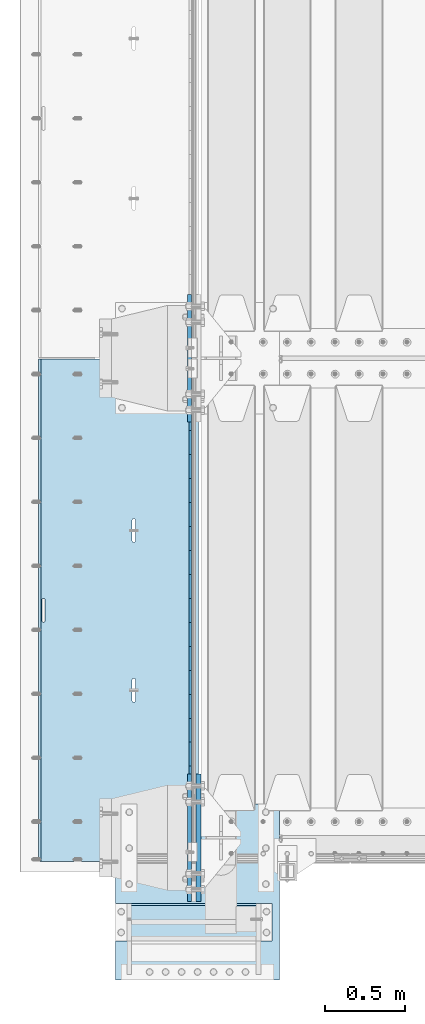
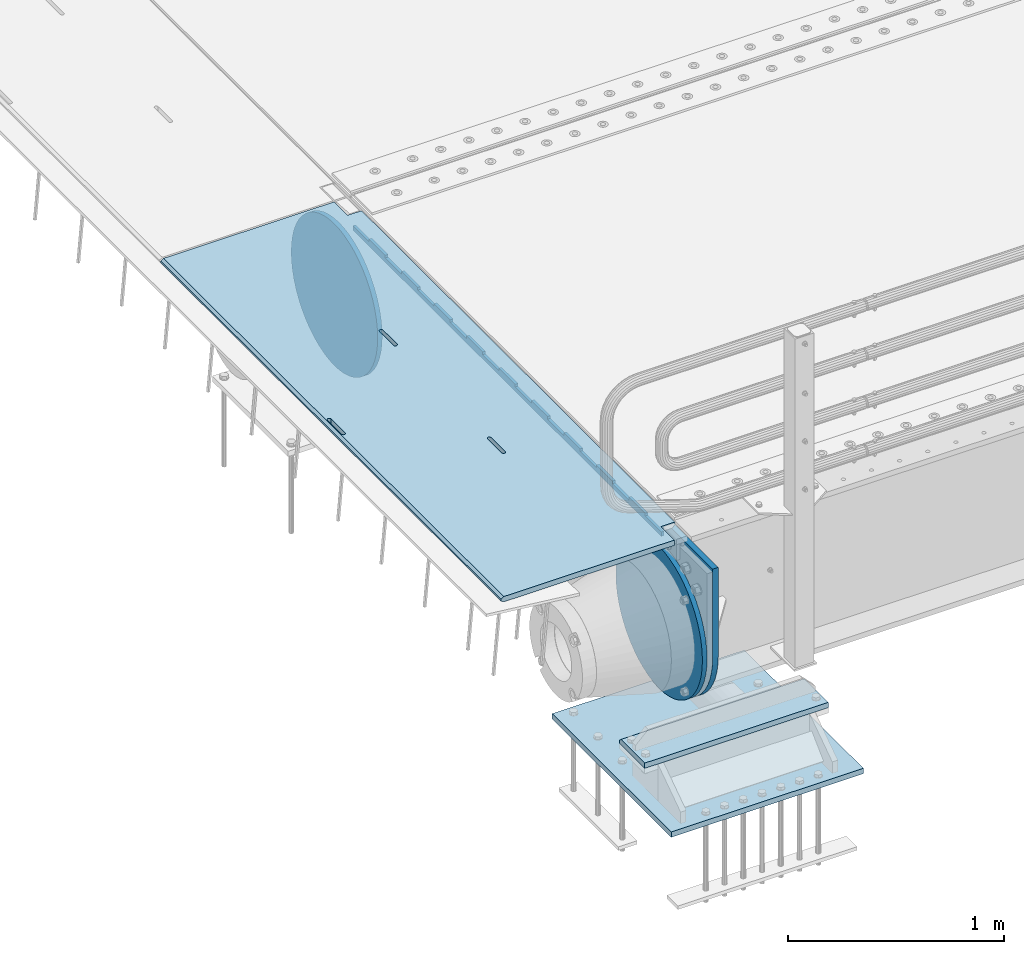
# One storey, part 189 of 247: 7 plates.
"""IFC2X3 building model written with IfcOpenShell, lengths in millimetres."""

from ifc_helpers import new_model, si_unit, frame, origin_with_axes, place, context, subcontext, project, spatial, faceted_brep, material, type_object, element, save


model = new_model("IFC2X3")

# Units and contexts
model_context = context("Model", 3, precision=1e-05, world=origin_with_axes())
body_context = subcontext(model_context, "Body", "Model", "MODEL_VIEW")
ifc_project = project(units=[si_unit("LENGTHUNIT", "METRE", prefix="MILLI"), si_unit("AREAUNIT", "SQUARE_METRE"), si_unit("VOLUMEUNIT", "CUBIC_METRE"), si_unit("MASSUNIT", "GRAM", prefix="KILO"), si_unit("TIMEUNIT", "SECOND"), si_unit("PLANEANGLEUNIT", "RADIAN"), si_unit("SOLIDANGLEUNIT", "STERADIAN"), si_unit("THERMODYNAMICTEMPERATUREUNIT", "DEGREE_CELSIUS"), si_unit("LUMINOUSINTENSITYUNIT", "LUMEN")], contexts=[model_context])

# Site, building, storey
site_placement = place(None, origin_with_axes())
site = spatial("IfcSite", under=ifc_project, at=site_placement, CompositionType="ELEMENT")
building_placement = place(site_placement, origin_with_axes())
building = spatial("IfcBuilding", under=site, at=building_placement, Name="Standard", CompositionType="ELEMENT")
storey_placement = place(building_placement, origin_with_axes())
storey = spatial("IfcBuildingStorey", under=building, at=storey_placement, Name="Undefined", CompositionType="ELEMENT", Elevation=0.0)

# Plates
ifc_material_1 = material(Name="STEEL/S355N")
plate_type_1 = type_object("IfcPlateType", PredefinedType="NOTDEFINED")
plate_1_placement = place(storey_placement, frame((-5.00375457088524, 2994.99992612933, -0.984429074950507), z_axis=(1.00000000012752e-09, -0.999999999987744, -4.95099999993936e-06), x_axis=(-0.999999999879068, -1.00000022172504e-09, -1.55519999981193e-05)))
element("IfcPlate", 1, at=plate_1_placement, inside=storey, type_object=plate_type_1, material=ifc_material_1, context=body_context, shape_type="Brep", body=[
    faceted_brep([(14.9998601691701, 15.0, 125.000024820866), (-0.000294611402138933, -0.00080690296905217, 124.999936248667), (-0.00191941583158695, 0.000806844427329922, 3020.00000492307), (14.9966216875132, 15.0, 3020.00007976655), (999.996459960937, 5.0, 1.36424205265939e-12), (984.996459960937, 15.0, 1.36424205265939e-12), (984.996459718778, 15.0, 3145.0), (999.996459718778, 5.0, 3145.0), (984.996459961366, -15.0, 1.81898940354586e-12), (999.996459960937, -4.99999999999999, 1.81898940354586e-12), (999.996459718778, -4.99999999999999, 3145.0), (984.996459719206, -15.0, 3145.0), (394.996621833771, -15.0000000044172, 1137.49999999819), (394.996621833771, 15.0, 1137.49999999819), (395.486056670582, 15.0, 1140.59016994194), (395.486056670582, -15.0000000044093, 1140.59016994194), (396.906451889569, 15.0, 1143.37785252112), (396.906451889569, -15.0000000043835, 1143.37785252112), (399.118769310224, 15.0, 1145.59016994194), (399.118769310224, -15.0000000043424, 1145.59016994194), (401.90645188929, 15.0, 1147.01056516114), (401.90645188929, -15.00000000429, 1147.01056516114), (404.996621832993, 15.0, 1147.49999999819), (404.996621832993, -15.0000000042314, 1147.49999999819), (408.086791776782, 15.0, 1147.01056516114), (408.086791776782, -15.0000000041723, 1147.01056516114), (410.874474356068, 15.0, 1145.59016994194), (410.874474356068, -15.0000000041186, 1145.59016994194), (413.086791777063, 15.0, 1143.37785252111), (413.086791777063, -15.0000000040755, 1143.37785252111), (414.507186996479, 15.0, 1140.59016994194), (414.507186996479, -15.0000000040472, 1140.59016994194), (414.996621833763, 15.0, 1137.49999999818), (414.996621833763, -15.0000000040365, 1137.49999999818), (414.996621843667, 15.0, 1007.49999999818), (414.996621843667, -15.000000003978, 1007.49999999818), (414.507187006854, 15.0, 1004.40983005444), (414.507187006854, -15.000000003986, 1004.40983005444), (413.086791787866, 15.0, 1001.62214747526), (413.086791787866, -15.0000000040118, 1001.62214747526), (410.874474367212, 15.0, 999.409830054441), (410.874474367212, -15.0000000040529, 999.409830054441), (408.086791788147, 15.0, 997.989434835241), (408.086791788147, -15.0000000041053, 997.989434835241), (404.996621844551, 15.0, 997.499999998192), (404.996621844551, -15.0000000041639, 997.499999998193), (401.906451900764, 15.0, 997.989434835241), (401.906451900764, -15.000000004223, 997.989434835241), (399.118769321479, 15.0, 999.409830054443), (399.118769321479, -15.0000000042767, 999.409830054443), (396.906451900484, 15.0, 1001.62214747527), (396.906451900484, -15.0000000043198, 1001.62214747527), (395.486056681068, 15.0, 1004.40983005444), (395.486056681068, -15.0000000043481, 1004.40983005444), (394.996621843781, 15.0, 1007.49999999819), (394.996621843781, -15.0000000043588, 1007.49999999819), (960.486056642574, -15.0, 1504.4098300542), (960.486056642574, 15.0, 1504.4098300542), (959.996621805288, 15.0, 1507.49999999795), (959.996621805288, -15.0, 1507.49999999795), (961.906451861991, -15.0, 1501.62214747502), (961.906451861991, 15.0, 1501.62214747502), (964.118769282986, -15.0, 1499.4098300542), (964.118769282986, 15.0, 1499.4098300542), (966.906451862271, -15.0, 1497.98943483499), (966.906451862271, 15.0, 1497.98943483499), (969.996621806058, -15.0, 1497.49999999795), (969.996621806058, 15.0, 1497.49999999795), (973.086791749653, -15.0, 1497.98943483499), (973.086791749654, 15.0, 1497.98943483499), (975.874474328718, -15.0, 1499.40983005419), (975.874474328718, 15.0, 1499.40983005419), (978.086791749372, -15.0, 1501.62214747502), (978.086791749372, 15.0, 1501.62214747502), (979.507186968361, -15.0, 1504.40983005419), (979.507186968361, 15.0, 1504.40983005419), (979.996621805173, -15.0, 1507.49999999794), (979.996621805173, 15.0, 1507.49999999794), (979.99662179527, -15.0, 1637.49999999794), (979.99662179527, 15.0, 1637.49999999794), (979.507186957986, -15.0, 1640.59016994169), (979.507186957985, 15.0, 1640.59016994169), (978.08679173857, -15.0, 1643.37785252087), (978.08679173857, 15.0, 1643.37785252087), (975.874474317574, -15.0, 1645.59016994169), (975.874474317574, 15.0, 1645.59016994169), (973.086791738289, -15.0, 1647.0105651609), (973.086791738289, 15.0, 1647.0105651609), (969.9966217945, -15.0, 1647.49999999795), (969.9966217945, 15.0, 1647.49999999795), (966.906451850796, -15.0, 1647.0105651609), (966.906451850796, 15.0, 1647.0105651609), (964.11876927173, -15.0, 1645.5901699417), (964.11876927173, 15.0, 1645.5901699417), (961.906451851076, -15.0, 1643.37785252087), (961.906451851076, 15.0, 1643.37785252087), (960.486056632089, -15.0, 1640.5901699417), (960.486056632089, 15.0, 1640.5901699417), (959.996621795278, -15.0, 1637.49999999795), (959.996621795278, 15.0, 1637.49999999795), (-0.000449375328786417, -14.9999999951864, 124.99986141778), (-0.000460362207132192, -15.00000004538, 3019.99993008594), (74.9964039657577, -15.0, 3019.99993015415), (74.9968705257564, 15.0, 3020.00007982415), (74.9962640908673, -15.0, 3145.0), (74.9967306508662, 15.0, 3145.0), (74.9997820614451, -15.0, 4.54747350886464e-13), (75.0002485914438, 15.0, 0.0), (74.9996421865538, -15.0000000127077, 124.999930084138), (75.0001087165527, 15.0, 125.000079754137), (395.486056593587, -15.0, 2140.59016994146), (396.906451812575, -15.0, 2143.37785252064), (399.118769233229, -15.0, 2145.59016994146), (401.906451812295, -15.0, 2147.01056516066), (404.996621755999, -15.0, 2147.49999999771), (408.086791699787, -15.0, 2147.01056516066), (410.874474279073, -15.0, 2145.59016994146), (413.086791700068, -15.0, 2143.37785252063), (414.507186919484, -15.0, 2140.59016994145), (414.996621756769, -15.0, 2137.4999999977), (414.996621766672, -15.0, 2007.4999999977), (414.50718692986, -15.0, 2004.40983005396), (413.086791710871, -15.0, 2001.62214747478), (410.874474290217, -15.0, 1999.40983005396), (408.086791711153, -15.0, 1997.98943483476), (404.996621767557, -15.0, 1997.49999999771), (401.90645182377, -15.0, 1997.98943483476), (399.118769244485, -15.0, 1999.40983005396), (396.90645182349, -15.0, 2001.62214747479), (395.486056604073, -15.0, 2004.40983005396), (394.996621766787, -15.0, 2007.49999999771), (394.996621756777, -15.0, 2137.49999999771), (396.90645182349, 15.0, 2001.62214747479), (395.486056604073, 15.0, 2004.40983005396), (399.118769244485, 15.0, 1999.40983005396), (401.90645182377, 15.0, 1997.98943483476), (404.996621767557, 15.0, 1997.49999999771), (408.086791711153, 15.0, 1997.98943483476), (410.874474290217, 15.0, 1999.40983005396), (413.086791710871, 15.0, 2001.62214747478), (414.50718692986, 15.0, 2004.40983005396), (414.996621766672, 15.0, 2007.4999999977), (414.996621756769, 15.0, 2137.4999999977), (414.507186919484, 15.0, 2140.59016994145), (413.086791700068, 15.0, 2143.37785252063), (410.874474279073, 15.0, 2145.59016994146), (408.086791699787, 15.0, 2147.01056516066), (404.996621755999, 15.0, 2147.49999999771), (401.906451812295, 15.0, 2147.01056516066), (399.118769233229, 15.0, 2145.59016994146), (396.906451812575, 15.0, 2143.37785252064), (395.486056593587, 15.0, 2140.59016994146), (394.996621756777, 15.0, 2137.49999999771), (394.996621766787, 15.0, 2007.49999999771)], [[[0, 1, 2, 3]], [[4, 5, 6, 7]], [[8, 9, 10, 11]], [[12, 13, 14, 15]], [[15, 14, 16, 17]], [[17, 16, 18, 19]], [[19, 18, 20, 21]], [[21, 20, 22, 23]], [[23, 22, 24, 25]], [[25, 24, 26, 27]], [[27, 26, 28, 29]], [[29, 28, 30, 31]], [[31, 30, 32, 33]], [[33, 32, 34, 35]], [[35, 34, 36, 37]], [[37, 36, 38, 39]], [[39, 38, 40, 41]], [[41, 40, 42, 43]], [[43, 42, 44, 45]], [[45, 44, 46, 47]], [[47, 46, 48, 49]], [[49, 48, 50, 51]], [[51, 50, 52, 53]], [[53, 52, 54, 55]], [[55, 54, 13, 12]], [[56, 57, 58, 59]], [[60, 61, 57, 56]], [[62, 63, 61, 60]], [[64, 65, 63, 62]], [[66, 67, 65, 64]], [[68, 69, 67, 66]], [[70, 71, 69, 68]], [[72, 73, 71, 70]], [[74, 75, 73, 72]], [[76, 77, 75, 74]], [[78, 79, 77, 76]], [[80, 81, 79, 78]], [[82, 83, 81, 80]], [[84, 85, 83, 82]], [[86, 87, 85, 84]], [[88, 89, 87, 86]], [[90, 91, 89, 88]], [[92, 93, 91, 90]], [[94, 95, 93, 92]], [[96, 97, 95, 94]], [[98, 99, 97, 96]], [[59, 58, 99, 98]], [[100, 101, 2, 1]], [[101, 102, 103, 3, 2]], [[104, 105, 103, 102]], [[105, 104, 11, 10, 7, 6]], [[10, 9, 4, 7]], [[9, 8, 106, 107, 5, 4]], [[106, 108, 109, 107]], [[109, 108, 100, 1, 0]], [[104, 102, 101, 100, 108, 106, 8, 11], [15, 17, 19, 21, 23, 25, 27, 29, 31, 33, 35, 37, 39, 41, 43, 45, 47, 49, 51, 53, 55, 12], [110, 111, 112, 113, 114, 115, 116, 117, 118, 119, 120, 121, 122, 123, 124, 125, 126, 127, 128, 129, 130, 131], [96, 94, 92, 90, 88, 86, 84, 82, 80, 78, 76, 74, 72, 70, 68, 66, 64, 62, 60, 56, 59, 98]], [[128, 132, 133, 129]], [[127, 134, 132, 128]], [[126, 135, 134, 127]], [[125, 136, 135, 126]], [[124, 137, 136, 125]], [[123, 138, 137, 124]], [[122, 139, 138, 123]], [[121, 140, 139, 122]], [[120, 141, 140, 121]], [[119, 142, 141, 120]], [[118, 143, 142, 119]], [[117, 144, 143, 118]], [[116, 145, 144, 117]], [[115, 146, 145, 116]], [[114, 147, 146, 115]], [[113, 148, 147, 114]], [[112, 149, 148, 113]], [[111, 150, 149, 112]], [[110, 151, 150, 111]], [[131, 152, 151, 110]], [[130, 153, 152, 131]], [[129, 133, 153, 130]], [[103, 105, 6, 5, 107, 109, 0, 3], [50, 48, 46, 44, 42, 40, 38, 36, 34, 32, 30, 28, 26, 24, 22, 20, 18, 16, 14, 13, 54, 52], [132, 134, 135, 136, 137, 138, 139, 140, 141, 142, 143, 144, 145, 146, 147, 148, 149, 150, 151, 152, 153, 133], [61, 63, 65, 67, 69, 71, 73, 75, 77, 79, 81, 83, 85, 87, 89, 91, 93, 95, 97, 99, 58, 57]]]),
])
ifc_material_2 = material()
plate_type_2 = type_object("IfcPlateType", PredefinedType="NOTDEFINED")
plate_2_placement = place(storey_placement, frame((455.000000735005, -645.000002936969, -803.000000000004), z_axis=(0.0, 1.0, 0.0), x_axis=(-1.0, 0.0, 0.0)))
element("IfcPlate", 2, at=plate_2_placement, inside=storey, type_object=plate_type_2, material=ifc_material_2, context=body_context, shape_type="Brep", body=[
    faceted_brep([(979.0, 0.0, 235.0), (979.0, 15.0, 220.0), (0.0, 15.0, 220.0), (0.0, 0.0, 235.0), (0.0, 15.0, 0.0), (0.0, -15.0, 0.0), (0.0, -15.0, 235.0), (979.0, -15.0, 235.0), (979.0, -15.0, 0.0), (979.0, 15.0, 0.0)], [[[0, 1, 2, 3]], [[4, 5, 6, 3, 2]], [[6, 7, 0, 3]], [[7, 8, 9, 1, 0]], [[8, 5, 4, 9]], [[9, 4, 2, 1]], [[8, 7, 6, 5]]]),
])
plate_type_3 = type_object("IfcPlateType", PredefinedType="NOTDEFINED")
plate_3_placement = place(storey_placement, frame((-523.999999999989, -890.0, -1043.0), z_axis=(1.0, 0.0, 0.0), x_axis=(0.0, 1.0, 0.0)))
element("IfcPlate", 3, at=plate_3_placement, inside=storey, type_object=plate_type_3, material=ifc_material_2, context=body_context, shape_type="Brep", body=[
    faceted_brep([(0.0, -15.0, 0.0), (2.93249286187347e-06, -15.0, 1025.0), (2.93249286187347e-06, 15.0, 1025.0), (0.0, 15.0, 0.0), (1100.0, -15.0, 1025.0), (1100.0, 15.0, 1025.0), (1100.0, -15.0, -1.9554136088118e-11), (1100.0, 15.0, -1.9554136088118e-11)], [[[0, 1, 2, 3]], [[1, 4, 5, 2]], [[4, 6, 7, 5]], [[6, 0, 3, 7]], [[5, 7, 3, 2]], [[6, 4, 1, 0]]]),
])
plate_type_4 = type_object("IfcPlateType", PredefinedType="NOTDEFINED")
plate_4_placement = place(storey_placement, frame((-57.5000000000039, 2847.50009937252, -35.9858217365063), z_axis=(1.00000000012752e-09, -0.999999999987744, -4.95099999993936e-06), x_axis=(0.0, 4.95099999111973e-06, -0.999999999987744)))
element("IfcPlate", 4, at=plate_4_placement, inside=storey, type_object=plate_type_4, material=ifc_material_1, context=body_context, shape_type="Brep", body=[
    faceted_brep([(0.0, -7.49999999999999, 0.0), (5.96145355302724e-12, -7.49999999999999, 150.0), (5.96145355302724e-12, 7.5, 150.0), (0.0, 7.5, 0.0), (-15.0000000000013, -7.49999999999999, 150.0), (-15.0000000000013, 7.5, 150.0), (-15.0000000000026, -7.49999999999999, 300.0), (-15.0000000000026, 7.5, 300.0), (1.00826014204358e-11, -7.49999999999999, 300.0), (1.00826014204358e-11, 7.5, 300.0), (1.05870867628255e-11, -7.49999999999999, 450.0), (1.05870867628255e-11, 7.5, 450.0), (-15.000000000004, -7.49999999999999, 450.0), (-15.000000000004, 7.5, 450.0), (-15.0000000000053, -7.49999999999999, 600.0), (-15.0000000000053, 7.5, 600.0), (1.65343294611375e-11, -7.49999999999999, 600.0), (1.65343294611375e-11, 7.5, 600.0), (1.88506987797155e-11, -7.49999999999999, 750.0), (1.88506987797155e-11, 7.5, 750.0), (-15.0000000000066, -7.49999999999999, 750.0), (-15.0000000000066, 7.5, 750.0), (-15.0000000000079, -7.49999999999999, 900.0), (-15.0000000000079, 7.5, 900.0), (2.48050469053851e-11, -7.49999999999999, 900.0), (2.48050469053851e-11, 7.5, 900.0), (2.7121416223963e-11, -7.49999999999999, 1050.0), (2.7121416223963e-11, 7.5, 1050.0), (-15.0000000000093, -7.49999999999999, 1050.0), (-15.0000000000093, 7.5, 1050.0), (-15.0000000000106, -7.49999999999999, 1200.0), (-15.0000000000106, 7.5, 1200.0), (3.12638803734444e-11, -7.49999999999999, 1200.0), (3.12638803734444e-11, 7.5, 1200.0), (3.53921336682106e-11, -7.49999999999999, 1350.0), (3.53921336682106e-11, 7.5, 1350.0), (-15.0000000000119, -7.49999999999999, 1350.0), (-15.0000000000119, 7.5, 1350.0), (-15.0000000000132, -7.49999999999999, 1500.0), (-15.0000000000132, 7.5, 1500.0), (3.77085029867885e-11, -7.49999999999999, 1500.0), (3.77085029867885e-11, 7.5, 1500.0), (4.36628511124582e-11, -7.49999999999999, 1650.0), (4.36628511124582e-11, 7.5, 1650.0), (-15.0000000000145, -7.49999999999999, 1650.0), (-15.0000000000145, 7.5, 1650.0), (-15.0000000000159, -7.49999999999999, 1800.0), (-15.0000000000159, 7.5, 1800.0), (4.41531256001326e-11, -7.49999999999999, 1800.0), (4.41531256001326e-11, 7.5, 1800.0), (4.82884843222564e-11, -7.49999999999999, 1950.0), (4.82884843222564e-11, 7.5, 1950.0), (-15.0000000000172, -7.49999999999999, 1950.0), (-15.0000000000172, 7.5, 1950.0), (-15.0000000000185, -7.49999999999999, 2100.0), (-15.0000000000185, 7.5, 2100.0), (5.24309484717378e-11, -7.49999999999999, 2100.0), (5.24309484717378e-11, 7.5, 2100.0), (5.47402123629581e-11, -7.49999999999999, 2250.0), (5.47402123629581e-11, 7.5, 2250.0), (-15.0000000000198, -7.49999999999999, 2250.0), (-15.0000000000198, 7.5, 2250.0), (-15.0000000000212, -7.49999999999999, 2400.0), (-15.0000000000212, 7.5, 2400.0), (6.06945604886278e-11, -7.49999999999999, 2400.0), (6.06945604886278e-11, 7.5, 2400.0), (6.30038243798481e-11, -7.49999999999999, 2550.0), (6.30038243798481e-11, 7.5, 2550.0), (-15.0000000000225, -7.49999999999999, 2550.0), (-15.0000000000225, 7.5, 2550.0), (-15.0000000000238, -7.49999999999999, 2700.0), (-15.0000000000238, 7.5, 2700.0), (6.53272991257836e-11, -7.49999999999999, 2700.0), (6.53272991257836e-11, 7.5, 2700.0), (7.12745418240957e-11, -7.49999999999999, 2850.0), (7.12745418240957e-11, 7.5, 2850.0), (24.9999999999749, -7.49999999999999, 2850.0), (24.9999999999749, 7.5, 2850.0), (25.0, -7.49999999999999, -1.81898940354586e-12), (25.0, 7.5, -1.81898940354586e-12)], [[[0, 1, 2, 3]], [[1, 4, 5, 2]], [[4, 6, 7, 5]], [[6, 8, 9, 7]], [[8, 10, 11, 9]], [[10, 12, 13, 11]], [[12, 14, 15, 13]], [[14, 16, 17, 15]], [[16, 18, 19, 17]], [[18, 20, 21, 19]], [[20, 22, 23, 21]], [[22, 24, 25, 23]], [[24, 26, 27, 25]], [[26, 28, 29, 27]], [[28, 30, 31, 29]], [[30, 32, 33, 31]], [[32, 34, 35, 33]], [[34, 36, 37, 35]], [[36, 38, 39, 37]], [[38, 40, 41, 39]], [[40, 42, 43, 41]], [[42, 44, 45, 43]], [[44, 46, 47, 45]], [[46, 48, 49, 47]], [[48, 50, 51, 49]], [[50, 52, 53, 51]], [[52, 54, 55, 53]], [[54, 56, 57, 55]], [[56, 58, 59, 57]], [[58, 60, 61, 59]], [[60, 62, 63, 61]], [[62, 64, 65, 63]], [[64, 66, 67, 65]], [[66, 68, 69, 67]], [[68, 70, 71, 69]], [[70, 72, 73, 71]], [[72, 74, 75, 73]], [[74, 76, 77, 75]], [[76, 78, 79, 77]], [[78, 0, 3, 79]], [[5, 7, 9, 11, 13, 15, 17, 19, 21, 23, 25, 27, 29, 31, 33, 35, 37, 39, 41, 43, 45, 47, 49, 51, 53, 55, 57, 59, 61, 63, 65, 67, 69, 71, 73, 75, 77, 79, 3, 2]], [[78, 76, 74, 72, 70, 68, 66, 64, 62, 60, 58, 56, 54, 52, 50, 48, 46, 44, 42, 40, 38, 36, 34, 32, 30, 28, 26, 24, 22, 20, 18, 16, 14, 12, 10, 8, 6, 4, 1, 0]]]),
])
plate_type_5 = type_object("IfcPlateType", PredefinedType="NOTDEFINED")
plate_5_placement = place(storey_placement, frame((-5.0, -400.0, -20.0), z_axis=(0.0, 1.0, 0.0), x_axis=(0.0, 0.0, -1.0)))
element("IfcPlate", 5, at=plate_5_placement, inside=storey, type_object=plate_type_5, material=ifc_material_1, context=body_context, shape_type="Brep", body=[
    faceted_brep([(855.0, -15.0, 572.963114671537), (855.0, 15.0, 572.963114671537), (849.182410261294, 15.0, 585.889268817531), (849.182410261294, -15.0, 585.889268817531), (824.193546357474, 15.0, 627.225898692485), (824.193546357474, -15.0, 627.225898692485), (794.404299268454, 15.0, 665.249063296341), (794.404299268454, -15.0, 665.249063296341), (760.249063296334, 15.0, 699.404299268464), (760.249063296334, -15.0, 699.404299268464), (722.22589869248, 15.0, 729.193546357486), (722.22589869248, -15.0, 729.193546357486), (680.889268817528, 15.0, 754.182410261309), (680.889268817528, -15.0, 754.182410261309), (636.841954817037, 15.0, 774.006497074193), (636.841954817037, -15.0, 774.006497074193), (590.726265715048, 15.0, 788.37672697045), (590.726265715048, -15.0, 788.37672697045), (543.214672102156, 15.0, 797.083549639254), (543.214672102156, -15.0, 797.083549639254), (495.0, -15.0, 800.000000000029), (495.0, 15.0, 800.0), (494.999999999412, -15.0, 0.0), (494.999999999412, 15.0, 0.0), (543.214672102129, 15.0, 2.91645036080718), (543.214672102129, -15.0, 2.91645036080718), (590.726265715023, 15.0, 11.6232730296083), (590.726265715023, -15.0, 11.6232730296083), (636.841954817014, 15.0, 25.9935029258631), (636.841954817014, -15.0, 25.9935029258631), (680.889268817507, 15.0, 45.817589738745), (680.889268817507, -15.0, 45.817589738745), (722.225898692462, 15.0, 70.8064536425663), (722.225898692462, -15.0, 70.8064536425663), (760.249063296318, 15.0, 100.595700731589), (760.249063296318, -15.0, 100.595700731589), (794.404299268441, 15.0, 134.750936703711), (794.404299268441, -15.0, 134.750936703711), (824.193546357463, 15.0, 172.774101307567), (824.193546357463, -15.0, 172.774101307567), (849.182410261284, 15.0, 214.110731182522), (849.182410261284, -15.0, 214.110731182522), (855.0, -15.0, 227.036885328536), (855.0, 15.0, 227.036885328536), (0.0, -15.0, 0.0), (0.0, 15.0, 0.0), (0.0, 15.0, 800.0), (0.0, -15.0, 800.0)], [[[0, 1, 2, 3]], [[3, 2, 4, 5]], [[5, 4, 6, 7]], [[7, 6, 8, 9]], [[9, 8, 10, 11]], [[11, 10, 12, 13]], [[13, 12, 14, 15]], [[15, 14, 16, 17]], [[17, 16, 18, 19]], [[20, 19, 18, 21]], [[22, 23, 24, 25]], [[25, 24, 26, 27]], [[27, 26, 28, 29]], [[29, 28, 30, 31]], [[31, 30, 32, 33]], [[33, 32, 34, 35]], [[35, 34, 36, 37]], [[37, 36, 38, 39]], [[39, 38, 40, 41]], [[42, 41, 40, 43]], [[42, 43, 1, 0]], [[44, 45, 23, 22]], [[16, 14, 12, 10, 8, 6, 4, 2, 1, 43, 40, 38, 36, 34, 32, 30, 28, 26, 24, 23, 45, 46, 21, 18]], [[44, 47, 46, 45]], [[46, 47, 20, 21]], [[47, 44, 22, 25, 27, 29, 31, 33, 35, 37, 39, 41, 42, 0, 3, 5, 7, 9, 11, 13, 15, 17, 19, 20]]]),
])
plate_type_6 = type_object("IfcPlateType", PredefinedType="NOTDEFINED")
plate_6_placement = place(storey_placement, frame((-62.5000000000001, 3400.0, -114.999999999998), z_axis=(0.0, 0.0, -1.0), x_axis=(0.0, -0.999999999999548, -9.5100000000016e-07)))
element("IfcPlate", 6, at=plate_6_placement, inside=storey, type_object=plate_type_6, material=ifc_material_1, context=body_context, shape_type="Brep", body=[
    faceted_brep([(0.0, -12.5, 400.0), (2.91645036077898, -12.5, 448.214672102129), (2.91645036077898, 12.5, 448.214672102129), (0.0, 12.5, 400.0), (11.6232730295797, -12.5, 495.726265715023), (11.6232730295797, 12.5, 495.726265715023), (25.993502925834, -12.5, 541.841954817014), (25.993502925834, 12.5, 541.841954817014), (45.8175897387155, -12.5, 585.889268817507), (45.8175897387155, 12.5, 585.889268817507), (70.8064536425372, -12.5, 627.225898692462), (70.8064536425372, 12.5, 627.225898692462), (100.595700731559, -12.5, 665.249063296318), (100.595700731559, 12.5, 665.249063296318), (134.750936703682, -12.5, 699.40429926844), (134.750936703682, 12.5, 699.40429926844), (172.774101307537, -12.5, 729.193546357462), (172.774101307537, 12.5, 729.193546357462), (214.110731182493, -12.5, 754.182410261284), (214.110731182493, 12.5, 754.182410261284), (258.158045182985, -12.5, 774.006497074166), (258.158045182985, 12.5, 774.006497074166), (304.273734284976, -12.5, 788.376726970421), (304.273734284976, 12.5, 788.376726970421), (351.785327897871, -12.5, 797.083549639221), (351.785327897871, 12.5, 797.083549639221), (400.0, -12.5, 800.0), (400.0, 12.5, 800.0), (448.214672102129, -12.5, 797.083549639222), (448.214672102129, 12.5, 797.083549639222), (495.726265715022, -12.5, 788.376726970421), (495.726265715022, 12.5, 788.376726970421), (541.841954817013, -12.5, 774.006497074166), (541.841954817013, 12.5, 774.006497074166), (585.889268817507, -12.5, 754.182410261284), (585.889268817507, 12.5, 754.182410261284), (627.225898692463, -12.5, 729.193546357463), (627.225898692463, 12.5, 729.193546357463), (665.249063296318, -12.5, 699.404299268441), (665.249063296318, 12.5, 699.404299268441), (699.404299268441, -12.5, 665.249063296318), (699.404299268441, 12.5, 665.249063296318), (729.193546357463, -12.5, 627.225898692462), (729.193546357463, 12.5, 627.225898692462), (754.182410261285, -12.5, 585.889268817507), (754.182410261285, 12.5, 585.889268817507), (774.006497074166, -12.5, 541.841954817014), (774.006497074166, 12.5, 541.841954817014), (788.37672697042, -12.5, 495.726265715023), (788.37672697042, 12.5, 495.726265715023), (797.083549639221, -12.5, 448.214672102129), (797.083549639221, 12.5, 448.214672102129), (800.0, -12.5, 400.0), (800.0, 12.5, 400.0), (797.083549639221, -12.5, 351.785327897871), (797.083549639221, 12.5, 351.785327897871), (788.37672697042, -12.5, 304.273734284977), (788.37672697042, 12.5, 304.273734284977), (774.006497074166, -12.5, 258.158045182986), (774.006497074166, 12.5, 258.158045182986), (754.182410261285, -12.5, 214.110731182493), (754.182410261285, 12.5, 214.110731182493), (729.193546357463, -12.5, 172.774101307538), (729.193546357463, 12.5, 172.774101307538), (699.404299268441, -12.5, 134.750936703682), (699.404299268441, 12.5, 134.750936703682), (665.249063296318, -12.5, 100.59570073156), (665.249063296318, 12.5, 100.59570073156), (627.225898692463, -12.5, 70.8064536425375), (627.225898692463, 12.5, 70.8064536425375), (585.889268817507, -12.5, 45.817589738716), (585.889268817507, 12.5, 45.817589738716), (541.841954817015, -12.5, 25.9935029258342), (541.841954817015, 12.5, 25.9935029258342), (495.726265715024, -12.5, 11.6232730295793), (495.726265715024, 12.5, 11.6232730295793), (448.214672102129, -12.5, 2.91645036077847), (448.214672102129, 12.5, 2.91645036077847), (400.0, -12.5, -5.6843418860808e-14), (400.0, 12.5, -5.6843418860808e-14), (351.785327897871, -12.5, 2.91645036077836), (351.785327897871, 12.5, 2.91645036077836), (304.273734284976, -12.5, 11.6232730295792), (304.273734284976, 12.5, 11.6232730295792), (258.158045182985, -12.5, 25.993502925834), (258.158045182985, 12.5, 25.993502925834), (214.110731182493, -12.5, 45.817589738716), (214.110731182493, 12.5, 45.817589738716), (172.774101307537, -12.5, 70.8064536425374), (172.774101307537, 12.5, 70.8064536425374), (134.750936703682, -12.5, 100.595700731559), (134.750936703682, 12.5, 100.595700731559), (100.595700731559, -12.5, 134.750936703682), (100.595700731559, 12.5, 134.750936703682), (70.8064536425372, -12.5, 172.774101307538), (70.8064536425372, 12.5, 172.774101307538), (45.8175897387155, -12.5, 214.110731182492), (45.8175897387155, 12.5, 214.110731182492), (25.993502925834, -12.5, 258.158045182986), (25.993502925834, 12.5, 258.158045182986), (11.6232730295797, -12.5, 304.273734284977), (11.6232730295797, 12.5, 304.273734284977), (2.91645036077898, -12.5, 351.785327897871), (2.91645036077898, 12.5, 351.785327897871)], [[[0, 1, 2, 3]], [[1, 4, 5, 2]], [[4, 6, 7, 5]], [[6, 8, 9, 7]], [[8, 10, 11, 9]], [[10, 12, 13, 11]], [[12, 14, 15, 13]], [[14, 16, 17, 15]], [[16, 18, 19, 17]], [[18, 20, 21, 19]], [[20, 22, 23, 21]], [[22, 24, 25, 23]], [[24, 26, 27, 25]], [[26, 28, 29, 27]], [[28, 30, 31, 29]], [[30, 32, 33, 31]], [[32, 34, 35, 33]], [[34, 36, 37, 35]], [[36, 38, 39, 37]], [[38, 40, 41, 39]], [[40, 42, 43, 41]], [[42, 44, 45, 43]], [[44, 46, 47, 45]], [[46, 48, 49, 47]], [[48, 50, 51, 49]], [[50, 52, 53, 51]], [[52, 54, 55, 53]], [[54, 56, 57, 55]], [[56, 58, 59, 57]], [[58, 60, 61, 59]], [[60, 62, 63, 61]], [[62, 64, 65, 63]], [[64, 66, 67, 65]], [[66, 68, 69, 67]], [[68, 70, 71, 69]], [[70, 72, 73, 71]], [[72, 74, 75, 73]], [[74, 76, 77, 75]], [[76, 78, 79, 77]], [[78, 80, 81, 79]], [[80, 82, 83, 81]], [[82, 84, 85, 83]], [[84, 86, 87, 85]], [[86, 88, 89, 87]], [[88, 90, 91, 89]], [[90, 92, 93, 91]], [[92, 94, 95, 93]], [[94, 96, 97, 95]], [[96, 98, 99, 97]], [[98, 100, 101, 99]], [[100, 102, 103, 101]], [[102, 0, 3, 103]], [[5, 7, 9, 11, 13, 15, 17, 19, 21, 23, 25, 27, 29, 31, 33, 35, 37, 39, 41, 43, 45, 47, 49, 51, 53, 55, 57, 59, 61, 63, 65, 67, 69, 71, 73, 75, 77, 79, 81, 83, 85, 87, 89, 91, 93, 95, 97, 99, 101, 103, 3, 2]], [[102, 100, 98, 96, 94, 92, 90, 88, 86, 84, 82, 80, 78, 76, 74, 72, 70, 68, 66, 64, 62, 60, 58, 56, 54, 52, 50, 48, 46, 44, 42, 40, 38, 36, 34, 32, 30, 28, 26, 24, 22, 20, 18, 16, 14, 12, 10, 8, 6, 4, 1, 0]]]),
])
plate_7_placement = place(storey_placement, frame((-62.5000000000001, 400.0, -114.999999999998), z_axis=(0.0, 0.0, -1.0), x_axis=(0.0, -0.999999999999548, -9.5100000000016e-07)))
element("IfcPlate", 7, at=plate_7_placement, inside=storey, type_object=plate_type_6, material=ifc_material_1, context=body_context, shape_type="Brep", body=[
    faceted_brep([(0.0, -12.5, 400.0), (2.91645036077898, -12.5, 448.214672102129), (2.91645036077898, 12.5, 448.214672102129), (0.0, 12.5, 400.0), (11.6232730295797, -12.5, 495.726265715023), (11.6232730295797, 12.5, 495.726265715023), (25.993502925834, -12.5, 541.841954817014), (25.993502925834, 12.5, 541.841954817014), (45.8175897387155, -12.5, 585.889268817507), (45.8175897387155, 12.5, 585.889268817507), (70.8064536425372, -12.5, 627.225898692462), (70.8064536425372, 12.5, 627.225898692462), (100.595700731559, -12.5, 665.249063296318), (100.595700731559, 12.5, 665.249063296318), (134.750936703682, -12.5, 699.40429926844), (134.750936703682, 12.5, 699.40429926844), (172.774101307537, -12.5, 729.193546357462), (172.774101307537, 12.5, 729.193546357462), (214.110731182493, -12.5, 754.182410261284), (214.110731182493, 12.5, 754.182410261284), (258.158045182985, -12.5, 774.006497074166), (258.158045182985, 12.5, 774.006497074166), (304.273734284976, -12.5, 788.376726970421), (304.273734284976, 12.5, 788.376726970421), (351.785327897871, -12.5, 797.083549639221), (351.785327897871, 12.5, 797.083549639221), (400.0, -12.5, 800.0), (400.0, 12.5, 800.0), (448.214672102129, -12.5, 797.083549639222), (448.214672102129, 12.5, 797.083549639222), (495.726265715022, -12.5, 788.376726970421), (495.726265715022, 12.5, 788.376726970421), (541.841954817013, -12.5, 774.006497074166), (541.841954817013, 12.5, 774.006497074166), (585.889268817507, -12.5, 754.182410261284), (585.889268817507, 12.5, 754.182410261284), (627.225898692463, -12.5, 729.193546357463), (627.225898692463, 12.5, 729.193546357463), (665.249063296318, -12.5, 699.404299268441), (665.249063296318, 12.5, 699.404299268441), (699.404299268441, -12.5, 665.249063296318), (699.404299268441, 12.5, 665.249063296318), (729.193546357463, -12.5, 627.225898692462), (729.193546357463, 12.5, 627.225898692462), (754.182410261285, -12.5, 585.889268817507), (754.182410261285, 12.5, 585.889268817507), (774.006497074166, -12.5, 541.841954817014), (774.006497074166, 12.5, 541.841954817014), (788.37672697042, -12.5, 495.726265715023), (788.37672697042, 12.5, 495.726265715023), (797.083549639221, -12.5, 448.214672102129), (797.083549639221, 12.5, 448.214672102129), (800.0, -12.5, 400.0), (800.0, 12.5, 400.0), (797.083549639221, -12.5, 351.785327897871), (797.083549639221, 12.5, 351.785327897871), (788.37672697042, -12.5, 304.273734284977), (788.37672697042, 12.5, 304.273734284977), (774.006497074166, -12.5, 258.158045182986), (774.006497074166, 12.5, 258.158045182986), (754.182410261285, -12.5, 214.110731182493), (754.182410261285, 12.5, 214.110731182493), (729.193546357463, -12.5, 172.774101307538), (729.193546357463, 12.5, 172.774101307538), (699.404299268441, -12.5, 134.750936703682), (699.404299268441, 12.5, 134.750936703682), (665.249063296318, -12.5, 100.59570073156), (665.249063296318, 12.5, 100.59570073156), (627.225898692463, -12.5, 70.8064536425375), (627.225898692463, 12.5, 70.8064536425375), (585.889268817507, -12.5, 45.817589738716), (585.889268817507, 12.5, 45.817589738716), (541.841954817015, -12.5, 25.9935029258342), (541.841954817015, 12.5, 25.9935029258342), (495.726265715024, -12.5, 11.6232730295793), (495.726265715024, 12.5, 11.6232730295793), (448.214672102129, -12.5, 2.91645036077847), (448.214672102129, 12.5, 2.91645036077847), (400.0, -12.5, -5.6843418860808e-14), (400.0, 12.5, -5.6843418860808e-14), (351.785327897871, -12.5, 2.91645036077836), (351.785327897871, 12.5, 2.91645036077836), (304.273734284976, -12.5, 11.6232730295792), (304.273734284976, 12.5, 11.6232730295792), (258.158045182985, -12.5, 25.993502925834), (258.158045182985, 12.5, 25.993502925834), (214.110731182493, -12.5, 45.817589738716), (214.110731182493, 12.5, 45.817589738716), (172.774101307537, -12.5, 70.8064536425374), (172.774101307537, 12.5, 70.8064536425374), (134.750936703682, -12.5, 100.595700731559), (134.750936703682, 12.5, 100.595700731559), (100.595700731559, -12.5, 134.750936703682), (100.595700731559, 12.5, 134.750936703682), (70.8064536425372, -12.5, 172.774101307538), (70.8064536425372, 12.5, 172.774101307538), (45.8175897387155, -12.5, 214.110731182492), (45.8175897387155, 12.5, 214.110731182492), (25.993502925834, -12.5, 258.158045182986), (25.993502925834, 12.5, 258.158045182986), (11.6232730295797, -12.5, 304.273734284977), (11.6232730295797, 12.5, 304.273734284977), (2.91645036077898, -12.5, 351.785327897871), (2.91645036077898, 12.5, 351.785327897871)], [[[0, 1, 2, 3]], [[1, 4, 5, 2]], [[4, 6, 7, 5]], [[6, 8, 9, 7]], [[8, 10, 11, 9]], [[10, 12, 13, 11]], [[12, 14, 15, 13]], [[14, 16, 17, 15]], [[16, 18, 19, 17]], [[18, 20, 21, 19]], [[20, 22, 23, 21]], [[22, 24, 25, 23]], [[24, 26, 27, 25]], [[26, 28, 29, 27]], [[28, 30, 31, 29]], [[30, 32, 33, 31]], [[32, 34, 35, 33]], [[34, 36, 37, 35]], [[36, 38, 39, 37]], [[38, 40, 41, 39]], [[40, 42, 43, 41]], [[42, 44, 45, 43]], [[44, 46, 47, 45]], [[46, 48, 49, 47]], [[48, 50, 51, 49]], [[50, 52, 53, 51]], [[52, 54, 55, 53]], [[54, 56, 57, 55]], [[56, 58, 59, 57]], [[58, 60, 61, 59]], [[60, 62, 63, 61]], [[62, 64, 65, 63]], [[64, 66, 67, 65]], [[66, 68, 69, 67]], [[68, 70, 71, 69]], [[70, 72, 73, 71]], [[72, 74, 75, 73]], [[74, 76, 77, 75]], [[76, 78, 79, 77]], [[78, 80, 81, 79]], [[80, 82, 83, 81]], [[82, 84, 85, 83]], [[84, 86, 87, 85]], [[86, 88, 89, 87]], [[88, 90, 91, 89]], [[90, 92, 93, 91]], [[92, 94, 95, 93]], [[94, 96, 97, 95]], [[96, 98, 99, 97]], [[98, 100, 101, 99]], [[100, 102, 103, 101]], [[102, 0, 3, 103]], [[5, 7, 9, 11, 13, 15, 17, 19, 21, 23, 25, 27, 29, 31, 33, 35, 37, 39, 41, 43, 45, 47, 49, 51, 53, 55, 57, 59, 61, 63, 65, 67, 69, 71, 73, 75, 77, 79, 81, 83, 85, 87, 89, 91, 93, 95, 97, 99, 101, 103, 3, 2]], [[102, 100, 98, 96, 94, 92, 90, 88, 86, 84, 82, 80, 78, 76, 74, 72, 70, 68, 66, 64, 62, 60, 58, 56, 54, 52, 50, 48, 46, 44, 42, 40, 38, 36, 34, 32, 30, 28, 26, 24, 22, 20, 18, 16, 14, 12, 10, 8, 6, 4, 1, 0]]]),
])

save(model, "model.ifc")
